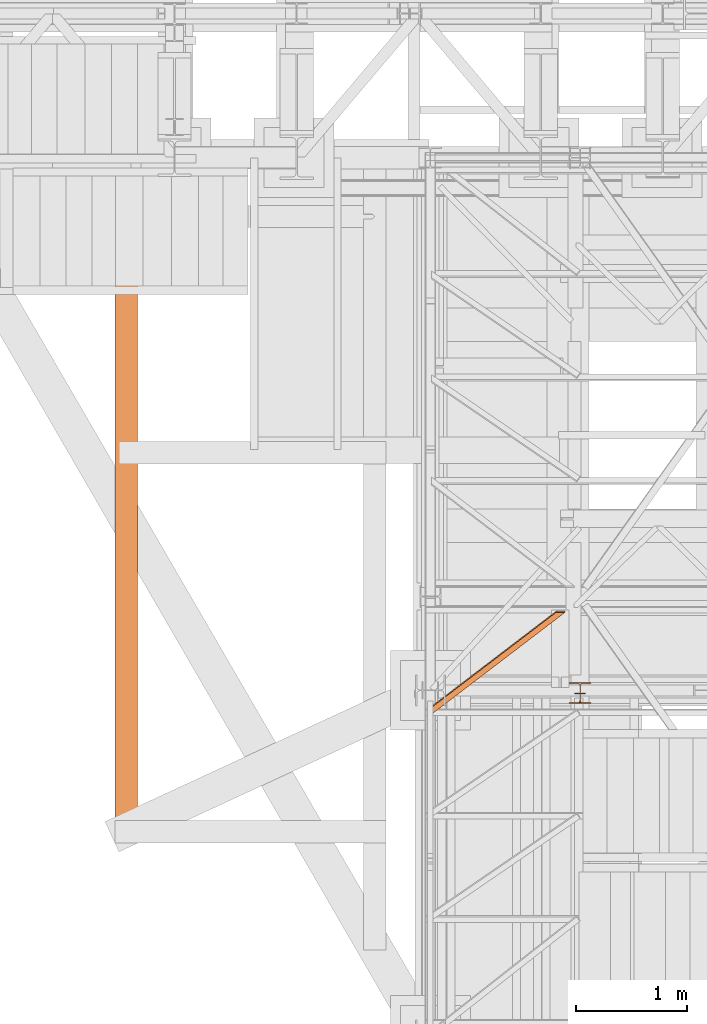
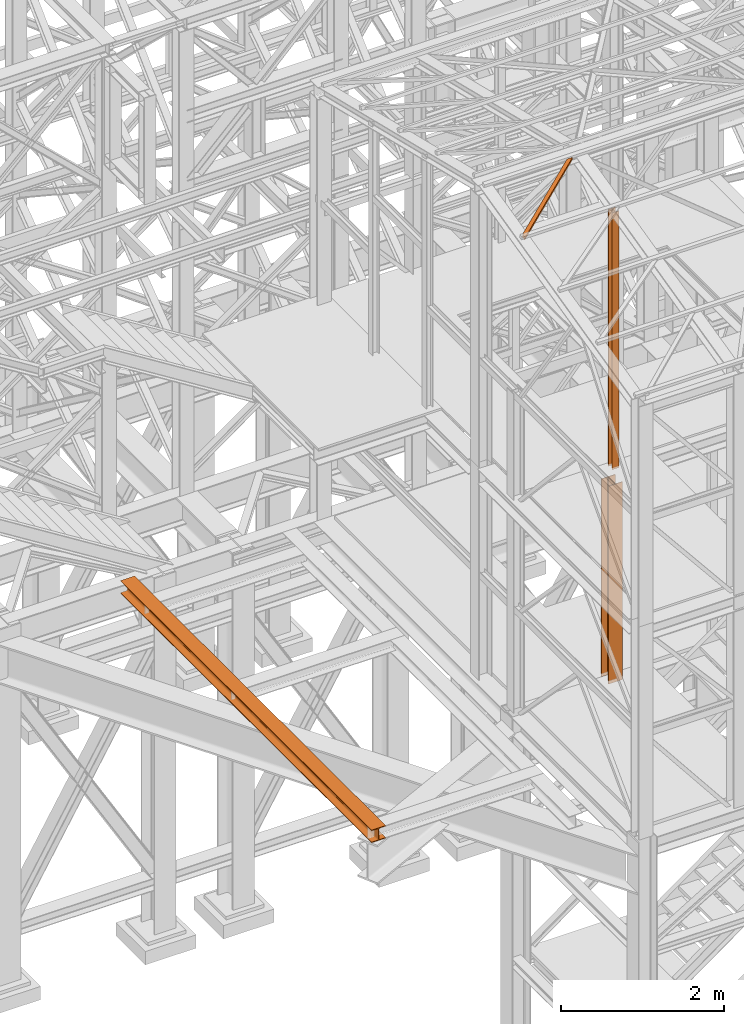
# One storey, part 16 of 208: 4 proxies.
"""IFC2X3 building model written with IfcOpenShell, lengths in millimetres."""

from ifc_helpers import new_model, entity, si_unit, converted_unit, frame, origin, origin_with_axes, place, context, subcontext, project, spatial, faceted_brep, element, save


model = new_model("IFC2X3")

# Units and contexts
model_context = context("Model", 3, precision=1e-05, world=origin())
plan_context = context("Plan", 3, precision=1e-05, world=origin())
body_context = subcontext(model_context, "Body", "Model", "MODEL_VIEW")
ifc_project = project(units=[si_unit("LENGTHUNIT", "METRE", prefix="MILLI"), converted_unit("PLANEANGLEUNIT", "DEGREE", entity("IfcPlaneAngleMeasure", 0.0174532925199433), si_unit("PLANEANGLEUNIT", "RADIAN"), dimensions=[0, 0, 0, 0, 0, 0, 0]), si_unit("AREAUNIT", "SQUARE_METRE"), si_unit("VOLUMEUNIT", "CUBIC_METRE")], contexts=[model_context, plan_context])

# Building, storey
building_placement = place(None, origin())
building = spatial("IfcBuilding", under=ifc_project, at=building_placement, CompositionType="COMPLEX")
storey_placement = place(building_placement, origin_with_axes())
storey = spatial("IfcBuildingStorey", under=building, at=storey_placement, Name="Geschoss", CompositionType="ELEMENT")

# Proxies
proxy_1_placement = place(storey_placement, frame((2448.254967038549, -22182.57439508626, 5284.990005364416), z_axis=(0.0, 0.0, 1.0), x_axis=(1.0, 0.0, 0.0)))
element("IfcBuildingElementProxy", 1, at=proxy_1_placement, inside=storey, context=body_context, shape_type="Brep", body=[
    faceted_brep([(0.01000000000021828, 190.0100125169738, 2970.00999254942), (200.0100029802325, 190.0100125169738, 2970.00999254942), (200.0100029802325, 180.0100146031364, 2970.00999254942), (121.2600035762789, 180.0100071525558, 2970.00999254942), (111.9441915473344, 178.1454621052726, 2970.00999254942), (105.1245498640838, 171.3258190250381, 2970.00999254942), (103.2600015571716, 162.0100079274162, 2970.00999254942), (103.2600015571716, 28.00999713897545, 2970.00999254942), (105.1245498640838, 18.69418604135353, 2970.00999254942), (111.9441915473344, 11.87454296111901, 2970.00999254942), (121.2600035762789, 10.00999791383583, 2970.00999254942), (200.0100029802325, 10.00999791383583, 2970.00999254942), (200.0100029802325, 0.00999999999839929, 2970.00999254942), (0.01000000000021828, 0.00999999999839929, 2970.00999254942), (0.01000000000021828, 10.00999791383583, 2970.00999254942), (78.75999940395377, 10.00999791383583, 2970.00999254942), (88.07581143289826, 11.87454296111901, 2970.00999254942), (94.89545311614893, 18.69418604135353, 2970.00999254942), (96.76000142306111, 28.00999713897545, 2970.00999254942), (96.76000142306111, 162.0100079274162, 2970.00999254942), (94.89545311614893, 171.3258190250381, 2970.00999254942), (88.07581143289826, 178.1454621052726, 2970.00999254942), (78.75999940395377, 180.0100071525558, 2970.00999254942), (0.01000000000021828, 180.0100146031364, 2970.00999254942), (200.0100029802325, 190.0100125169738, 2970.00999254942), (0.01000000000021828, 190.0100125169738, 2970.00999254942), (0.01000000000021828, 190.0100125169738, 0.009999999999308784), (200.0100029802325, 190.0100125169738, 0.009999999999308784), (200.0100029802325, 180.0100146031364, 2970.00999254942), (200.0100029802325, 190.0100125169738, 2970.00999254942), (200.0100029802325, 190.0100125169738, 0.009999999999308784), (200.0100029802325, 180.0100146031364, 0.009999999999308784), (121.2600035762789, 180.0100071525558, 2970.00999254942), (200.0100029802325, 180.0100146031364, 2970.00999254942), (200.0100029802325, 180.0100146031364, 0.009999999999308784), (121.2600035762789, 180.0100071525558, 0.009999999999308784), (111.9441915473344, 178.1454621052726, 2970.00999254942), (121.2600035762789, 180.0100071525558, 2970.00999254942), (121.2600035762789, 180.0100071525558, 0.009999999999308784), (111.9441915473344, 178.1454621052726, 0.009999999999308784), (105.1245498640838, 171.3258190250381, 2970.00999254942), (111.9441915473344, 178.1454621052726, 2970.00999254942), (111.9441915473344, 178.1454621052726, 0.009999999999308784), (105.1245498640838, 171.3258190250381, 0.009999999999308784), (103.2600015571716, 162.0100079274162, 2970.00999254942), (105.1245498640838, 171.3258190250381, 2970.00999254942), (105.1245498640838, 171.3258190250381, 0.009999999999308784), (103.2600015571716, 162.0100079274162, 0.009999999999308784), (103.2600015571716, 28.00999713897545, 2970.00999254942), (103.2600015571716, 162.0100079274162, 2970.00999254942), (103.2600015571716, 162.0100079274162, 0.009999999999308784), (103.2600015571716, 28.00999713897545, 0.009999999999308784), (105.1245498640838, 18.69418604135353, 2970.00999254942), (103.2600015571716, 28.00999713897545, 2970.00999254942), (103.2600015571716, 28.00999713897545, 0.009999999999308784), (105.1245498640838, 18.69418604135353, 0.009999999999308784), (111.9441915473344, 11.87454296111901, 2970.00999254942), (105.1245498640838, 18.69418604135353, 2970.00999254942), (105.1245498640838, 18.69418604135353, 0.009999999999308784), (111.9441915473344, 11.87454296111901, 0.009999999999308784), (121.2600035762789, 10.00999791383583, 2970.00999254942), (111.9441915473344, 11.87454296111901, 2970.00999254942), (111.9441915473344, 11.87454296111901, 0.009999999999308784), (121.2600035762789, 10.00999791383583, 0.009999999999308784), (200.0100029802325, 10.00999791383583, 2970.00999254942), (121.2600035762789, 10.00999791383583, 2970.00999254942), (121.2600035762789, 10.00999791383583, 0.009999999999308784), (200.0100029802325, 10.00999791383583, 0.009999999999308784), (200.0100029802325, 0.00999999999839929, 2970.00999254942), (200.0100029802325, 10.00999791383583, 2970.00999254942), (200.0100029802325, 10.00999791383583, 0.009999999999308784), (200.0100029802325, 0.00999999999839929, 0.009999999999308784), (0.01000000000021828, 0.00999999999839929, 2970.00999254942), (200.0100029802325, 0.00999999999839929, 2970.00999254942), (200.0100029802325, 0.00999999999839929, 0.009999999999308784), (0.01000000000021828, 0.00999999999839929, 0.009999999999308784), (0.01000000000021828, 10.00999791383583, 2970.00999254942), (0.01000000000021828, 0.00999999999839929, 2970.00999254942), (0.01000000000021828, 0.00999999999839929, 0.009999999999308784), (0.01000000000021828, 10.00999791383583, 0.009999999999308784), (78.75999940395377, 10.00999791383583, 2970.00999254942), (0.01000000000021828, 10.00999791383583, 2970.00999254942), (0.01000000000021828, 10.00999791383583, 0.009999999999308784), (78.75999940395377, 10.00999791383583, 0.009999999999308784), (88.07581143289826, 11.87454296111901, 2970.00999254942), (78.75999940395377, 10.00999791383583, 2970.00999254942), (78.75999940395377, 10.00999791383583, 0.009999999999308784), (88.07581143289826, 11.87454296111901, 0.009999999999308784), (94.89545311614893, 18.69418604135353, 2970.00999254942), (88.07581143289826, 11.87454296111901, 2970.00999254942), (88.07581143289826, 11.87454296111901, 0.009999999999308784), (94.89545311614893, 18.69418604135353, 0.009999999999308784), (96.76000142306111, 28.00999713897545, 2970.00999254942), (94.89545311614893, 18.69418604135353, 2970.00999254942), (94.89545311614893, 18.69418604135353, 0.009999999999308784), (96.76000142306111, 28.00999713897545, 0.009999999999308784), (96.76000142306111, 162.0100079274162, 2970.00999254942), (96.76000142306111, 28.00999713897545, 2970.00999254942), (96.76000142306111, 28.00999713897545, 0.009999999999308784), (96.76000142306111, 162.0100079274162, 0.009999999999308784), (94.89545311614893, 171.3258190250381, 2970.00999254942), (96.76000142306111, 162.0100079274162, 2970.00999254942), (96.76000142306111, 162.0100079274162, 0.009999999999308784), (94.89545311614893, 171.3258190250381, 0.009999999999308784), (88.07581143289826, 178.1454621052726, 2970.00999254942), (94.89545311614893, 171.3258190250381, 2970.00999254942), (94.89545311614893, 171.3258190250381, 0.009999999999308784), (88.07581143289826, 178.1454621052726, 0.009999999999308784), (78.75999940395377, 180.0100071525558, 2970.00999254942), (88.07581143289826, 178.1454621052726, 2970.00999254942), (88.07581143289826, 178.1454621052726, 0.009999999999308784), (78.75999940395377, 180.0100071525558, 0.009999999999308784), (0.01000000000021828, 180.0100146031364, 2970.00999254942), (78.75999940395377, 180.0100071525558, 2970.00999254942), (78.75999940395377, 180.0100071525558, 0.009999999999308784), (0.01000000000021828, 180.0100146031364, 0.009999999999308784), (0.01000000000021828, 190.0100125169738, 2970.00999254942), (0.01000000000021828, 180.0100146031364, 2970.00999254942), (0.01000000000021828, 180.0100146031364, 0.009999999999308784), (0.01000000000021828, 190.0100125169738, 0.009999999999308784), (0.01000000000021828, 190.0100125169738, 0.009999999999308784), (0.01000000000021828, 180.0100146031364, 0.009999999999308784), (78.75999940395377, 180.0100071525558, 0.009999999999308784), (88.07581143289826, 178.1454621052726, 0.009999999999308784), (94.89545311614893, 171.3258190250381, 0.009999999999308784), (96.76000142306111, 162.0100079274162, 0.009999999999308784), (96.76000142306111, 28.00999713897545, 0.009999999999308784), (94.89545311614893, 18.69418604135353, 0.009999999999308784), (88.07581143289826, 11.87454296111901, 0.009999999999308784), (78.75999940395377, 10.00999791383583, 0.009999999999308784), (0.01000000000021828, 10.00999791383583, 0.009999999999308784), (0.01000000000021828, 0.00999999999839929, 0.009999999999308784), (200.0100029802325, 0.00999999999839929, 0.009999999999308784), (200.0100029802325, 10.00999791383583, 0.009999999999308784), (121.2600035762789, 10.00999791383583, 0.009999999999308784), (111.9441915473344, 11.87454296111901, 0.009999999999308784), (105.1245498640838, 18.69418604135353, 0.009999999999308784), (103.2600015571716, 28.00999713897545, 0.009999999999308784), (103.2600015571716, 162.0100079274162, 0.009999999999308784), (105.1245498640838, 171.3258190250381, 0.009999999999308784), (111.9441915473344, 178.1454621052726, 0.009999999999308784), (121.2600035762789, 180.0100071525558, 0.009999999999308784), (200.0100029802325, 180.0100146031364, 0.009999999999308784), (200.0100029802325, 190.0100125169738, 0.009999999999308784)], [[[0, 1, 2, 3, 4, 5, 6, 7, 8, 9, 10, 11, 12, 13, 14, 15, 16, 17, 18, 19, 20, 21, 22, 23]], [[24, 25, 26, 27]], [[28, 29, 30, 31]], [[32, 33, 34, 35]], [[36, 37, 38, 39]], [[40, 41, 42, 43]], [[44, 45, 46, 47]], [[48, 49, 50, 51]], [[52, 53, 54, 55]], [[56, 57, 58, 59]], [[60, 61, 62, 63]], [[64, 65, 66, 67]], [[68, 69, 70, 71]], [[72, 73, 74, 75]], [[76, 77, 78, 79]], [[80, 81, 82, 83]], [[84, 85, 86, 87]], [[88, 89, 90, 91]], [[92, 93, 94, 95]], [[96, 97, 98, 99]], [[100, 101, 102, 103]], [[104, 105, 106, 107]], [[108, 109, 110, 111]], [[112, 113, 114, 115]], [[116, 117, 118, 119]], [[120, 121, 122, 123, 124, 125, 126, 127, 128, 129, 130, 131, 132, 133, 134, 135, 136, 137, 138, 139, 140, 141, 142, 143]]], orient=[[False], [False], [False], [False], [False], [False], [False], [False], [False], [False], [False], [False], [False], [False], [False], [False], [False], [False], [False], [False], [False], [False], [False], [False], [False], [False]]),
])
proxy_2_placement = place(storey_placement, frame((2498.31966389647, -22182.57439787535, 8484.990002086157), z_axis=(0.0, 0.0, 1.0), x_axis=(1.0, 0.0, 0.0)))
element("IfcBuildingElementProxy", 2, at=proxy_2_placement, inside=storey, context=body_context, shape_type="Brep", body=[
    faceted_brep([(0.01000000000021828, 8.010000000002037, 0.01000000000021828), (0.01000000000021828, 0.01000000000203727, 0.01000000000021828), (100.0100000000002, 0.01000000000203727, 0.01000000000021828), (100.0100000000002, 8.010000000002037, 0.01000000000021828), (52.51000000000022, 8.010000000002037, 0.01000000000021828), (52.51000000000022, 88.01000000000204, 0.01000000000021828), (100.0100000000002, 88.01000000000204, 0.01000000000021828), (100.0100000000002, 96.01000000000204, 0.01000000000021828), (0.01000000000021828, 96.01000000000204, 0.01000000000021828), (0.01000000000021828, 88.01000000000204, 0.01000000000021828), (47.51000000000022, 88.01000000000204, 0.01000000000021828), (47.51000000000022, 8.010000000002037, 0.01000000000021828), (0.01000000000021828, 0.01000000000203727, 0.01000000000021828), (0.01000000000021828, 8.010000000002037, 0.01000000000021828), (0.01000000000203727, 8.0099999999984, 3855.922025344464), (0.01000000000203727, 0.00999999999839929, 3855.922025344464), (100.0100000000002, 0.01000000000203727, 0.01000000000021828), (0.01000000000021828, 0.01000000000203727, 0.01000000000021828), (0.01000000000203727, 0.00999999999839929, 3855.922025344464), (100.010000000002, 0.00999999999839929, 3855.922025344464), (100.0100000000002, 8.010000000002037, 0.01000000000021828), (100.0100000000002, 0.01000000000203727, 0.01000000000021828), (100.010000000002, 0.00999999999839929, 3855.922025344464), (100.010000000002, 8.0099999999984, 3855.922025344464), (52.51000000000022, 8.010000000002037, 0.01000000000021828), (100.0100000000002, 8.010000000002037, 0.01000000000021828), (100.010000000002, 8.0099999999984, 3855.922025344464), (52.51000000000204, 8.0099999999984, 3855.922025344464), (52.51000000000022, 88.01000000000204, 0.01000000000021828), (52.51000000000022, 8.010000000002037, 0.01000000000021828), (52.51000000000204, 8.0099999999984, 3855.922025344464), (52.51000000000204, 88.0099999999984, 3855.922025344464), (100.0100000000002, 88.01000000000204, 0.01000000000021828), (52.51000000000022, 88.01000000000204, 0.01000000000021828), (52.51000000000204, 88.0099999999984, 3855.922025344464), (100.010000000002, 88.0099999999984, 3855.922025344464), (100.0100000000002, 96.01000000000204, 0.01000000000021828), (100.0100000000002, 88.01000000000204, 0.01000000000021828), (100.010000000002, 88.0099999999984, 3855.922025344464), (100.010000000002, 96.0099999999984, 3855.922025344464), (0.01000000000021828, 96.01000000000204, 0.01000000000021828), (100.0100000000002, 96.01000000000204, 0.01000000000021828), (100.010000000002, 96.0099999999984, 3855.922025344464), (0.01000000000203727, 96.0099999999984, 3855.922025344464), (0.01000000000021828, 88.01000000000204, 0.01000000000021828), (0.01000000000021828, 96.01000000000204, 0.01000000000021828), (0.01000000000203727, 96.0099999999984, 3855.922025344464), (0.01000000000203727, 88.0099999999984, 3855.922025344464), (47.51000000000022, 88.01000000000204, 0.01000000000021828), (0.01000000000021828, 88.01000000000204, 0.01000000000021828), (0.01000000000203727, 88.0099999999984, 3855.922025344464), (47.51000000000204, 88.0099999999984, 3855.922025344464), (47.51000000000022, 8.010000000002037, 0.01000000000021828), (47.51000000000022, 88.01000000000204, 0.01000000000021828), (47.51000000000204, 88.0099999999984, 3855.922025344464), (47.51000000000204, 8.0099999999984, 3855.922025344464), (0.01000000000021828, 8.010000000002037, 0.01000000000021828), (47.51000000000022, 8.010000000002037, 0.01000000000021828), (47.51000000000204, 8.0099999999984, 3855.922025344464), (0.01000000000203727, 8.0099999999984, 3855.922025344464), (0.01000000000203727, 8.0099999999984, 3855.922025344464), (47.51000000000204, 8.0099999999984, 3855.922025344464), (47.51000000000204, 88.0099999999984, 3855.922025344464), (0.01000000000203727, 88.0099999999984, 3855.922025344464), (0.01000000000203727, 96.0099999999984, 3855.922025344464), (100.010000000002, 96.0099999999984, 3855.922025344464), (100.010000000002, 88.0099999999984, 3855.922025344464), (52.51000000000204, 88.0099999999984, 3855.922025344464), (52.51000000000204, 8.0099999999984, 3855.922025344464), (100.010000000002, 8.0099999999984, 3855.922025344464), (100.010000000002, 0.00999999999839929, 3855.922025344464), (0.01000000000203727, 0.00999999999839929, 3855.922025344464)], [[[0, 1, 2, 3, 4, 5, 6, 7, 8, 9, 10, 11]], [[12, 13, 14, 15]], [[16, 17, 18, 19]], [[20, 21, 22, 23]], [[24, 25, 26, 27]], [[28, 29, 30, 31]], [[32, 33, 34, 35]], [[36, 37, 38, 39]], [[40, 41, 42, 43]], [[44, 45, 46, 47]], [[48, 49, 50, 51]], [[52, 53, 54, 55]], [[56, 57, 58, 59]], [[60, 61, 62, 63, 64, 65, 66, 67, 68, 69, 70, 71]]], orient=[[False], [False], [False], [False], [False], [False], [False], [False], [False], [False], [False], [False], [False], [False]]),
])
proxy_3_placement = place(storey_placement, frame((-1641.745031471337, -23437.50386180536, 5094.990005364416), z_axis=(0.0, 0.0, 1.0), x_axis=(1.0, 0.0, 0.0)))
element("IfcBuildingElementProxy", 3, at=proxy_3_placement, inside=storey, context=body_context, shape_type="Brep", body=[
    faceted_brep([(200.01, 6180.010000000002, 0.01000000000021828), (200.01, 0.01000000000203727, 0.01000000000021828), (200.01, 0.01000000000203727, 10.01000000000022), (200.01, 6180.010000000002, 10.01000000000022), (200.01, 6180.010000000002, 10.01000000000022), (200.01, 0.01000000000203727, 10.01000000000022), (121.26, 0.01000000000203727, 10.01000000000022), (121.26, 6180.010000000002, 10.01000000000022), (121.26, 6180.010000000002, 10.01000000000022), (121.26, 0.01000000000203727, 10.01000000000022), (115.6977129694258, 0.01000000000203727, 10.89104403849342), (115.6977129694258, 6180.010000000002, 10.89104403849342), (115.6977129694258, 6180.010000000002, 10.89104403849342), (115.6977129694258, 0.01000000000203727, 10.89104403849342), (110.6798832894654, 0.01000000000203727, 13.44771635773213), (110.6798832894654, 6180.010000000002, 13.44771635773213), (110.6798832894654, 6180.010000000002, 13.44771635773213), (110.6798832894654, 0.01000000000203727, 13.44771635773213), (106.6977163577337, 0.01000000000203727, 17.42988328946558), (106.6977163577337, 6180.010000000002, 17.42988328946558), (106.6977163577337, 6180.010000000002, 17.42988328946558), (106.6977163577337, 0.01000000000203727, 17.42988328946558), (104.141044038495, 0.01000000000203727, 22.44771296942599), (104.141044038495, 6180.010000000002, 22.44771296942599), (104.141044038495, 6180.010000000002, 22.44771296942599), (104.141044038495, 0.01000000000203727, 22.44771296942599), (103.26, 0.01000000000203727, 28.01000000000022), (103.26, 6180.010000000002, 28.01000000000022), (103.26, 6180.010000000002, 28.01000000000022), (103.26, 0.01000000000203727, 28.01000000000022), (103.26, 0.01000000000203727, 162.0100000000002), (103.26, 6180.010000000002, 162.0100000000002), (103.26, 6180.010000000002, 162.0100000000002), (103.26, 0.01000000000203727, 162.0100000000002), (104.141044038495, 0.01000000000203727, 167.5722870305744), (104.141044038495, 6180.010000000002, 167.5722870305744), (104.141044038495, 6180.010000000002, 167.5722870305744), (104.141044038495, 0.01000000000203727, 167.5722870305744), (106.6977163577337, 0.01000000000203727, 172.5901167105349), (106.6977163577337, 6180.010000000002, 172.5901167105349), (106.6977163577337, 6180.010000000002, 172.5901167105349), (106.6977163577337, 0.01000000000203727, 172.5901167105349), (110.6798832894672, 0.01000000000203727, 176.5722836422674), (110.6798832894654, 6180.010000000002, 176.5722836422683), (110.6798832894654, 6180.010000000002, 176.5722836422683), (110.6798832894672, 0.01000000000203727, 176.5722836422674), (115.6977129694258, 0.01000000000203727, 179.128955961507), (115.6977129694258, 6180.010000000002, 179.128955961507), (115.6977129694258, 6180.010000000002, 179.128955961507), (115.6977129694258, 0.01000000000203727, 179.128955961507), (120.01, 0.01000000000203727, 180.0100000000002), (120.01, 6180.010000000002, 180.0100000000002), (120.01, 6180.010000000002, 180.0100000000002), (120.01, 0.01000000000203727, 180.0100000000002), (200.01, 0.01000000000203727, 180.0100000000002), (200.01, 6180.010000000002, 180.0100000000002), (200.01, 6180.010000000002, 180.0100000000002), (200.01, 0.01000000000203727, 180.0100000000002), (200.01, 0.01000000000203727, 190.0100000000002), (200.01, 6180.010000000002, 190.0100000000002), (200.01, 6180.010000000002, 190.0100000000002), (200.01, 0.01000000000203727, 190.0100000000002), (0.009999999999990905, 0.01000000000203727, 190.0100000000002), (0.009999999999990905, 6180.010000000002, 190.0100000000002), (0.009999999999990905, 6180.010000000002, 190.0100000000002), (0.009999999999990905, 0.01000000000203727, 190.0100000000002), (0.009999999999990905, 0.01000000000203727, 180.0100000000002), (0.009999999999990905, 6180.010000000002, 180.0100000000002), (0.009999999999990905, 6180.010000000002, 180.0100000000002), (0.009999999999990905, 0.01000000000203727, 180.0100000000002), (78.75999999999999, 0.01000000000203727, 180.0100000000002), (78.75999999999999, 6180.010000000002, 180.0100000000002), (78.75999999999999, 6180.010000000002, 180.0100000000002), (78.75999999999999, 0.01000000000203727, 180.0100000000002), (84.32228703057422, 0.01000000000203727, 179.128955961507), (84.32228703057422, 6180.010000000002, 179.128955961507), (84.32228703057422, 6180.010000000002, 179.128955961507), (84.32228703057422, 0.01000000000203727, 179.128955961507), (89.34011671053463, 0.01000000000203727, 176.5722836422683), (89.34011671053463, 6180.010000000002, 176.5722836422683), (89.34011671053463, 6180.010000000002, 176.5722836422683), (89.34011671053463, 0.01000000000203727, 176.5722836422683), (93.32228364227171, 0.01000000000203727, 172.5901167105349), (93.3222836422699, 6180.010000000002, 172.5901167105349), (93.3222836422699, 6180.010000000002, 172.5901167105349), (93.32228364227171, 0.01000000000203727, 172.5901167105349), (95.87895596150497, 0.01000000000203727, 167.5722870305744), (95.87895596150497, 6180.010000000002, 167.5722870305744), (95.87895596150497, 6180.010000000002, 167.5722870305744), (95.87895596150497, 0.01000000000203727, 167.5722870305744), (96.75999999999999, 0.01000000000203727, 162.0100000000002), (96.75999999999999, 6180.010000000002, 162.0100000000002), (96.75999999999999, 6180.010000000002, 162.0100000000002), (96.75999999999999, 0.01000000000203727, 162.0100000000002), (96.75999999999999, 0.01000000000203727, 28.01000000000022), (96.75999999999999, 6180.010000000002, 28.01000000000022), (96.75999999999999, 6180.010000000002, 28.01000000000022), (96.75999999999999, 0.01000000000203727, 28.01000000000022), (95.87895596150497, 0.01000000000203727, 22.44771296942599), (95.87895596150497, 6180.010000000002, 22.44771296942599), (95.87895596150497, 6180.010000000002, 22.44771296942599), (95.87895596150497, 0.01000000000203727, 22.44771296942599), (93.3222836422699, 0.01000000000203727, 17.42988328946558), (93.3222836422699, 6180.010000000002, 17.42988328946558), (93.3222836422699, 6180.010000000002, 17.42988328946558), (93.3222836422699, 0.01000000000203727, 17.42988328946558), (89.34011671053463, 0.01000000000203727, 13.44771635773213), (89.34011671053463, 6180.010000000002, 13.44771635773213), (89.34011671053463, 6180.010000000002, 13.44771635773213), (89.34011671053463, 0.01000000000203727, 13.44771635773213), (84.32228703057422, 0.01000000000203727, 10.89104403849342), (84.32228703057422, 6180.010000000002, 10.89104403849342), (84.32228703057422, 6180.010000000002, 10.89104403849342), (84.32228703057422, 0.01000000000203727, 10.89104403849342), (78.75999999999999, 0.01000000000203727, 10.01000000000022), (78.75999999999999, 6180.010000000002, 10.01000000000022), (78.75999999999999, 6180.010000000002, 10.01000000000022), (78.75999999999999, 0.01000000000203727, 10.01000000000022), (0.009999999999990905, 0.01000000000203727, 10.01000000000022), (0.009999999999990905, 6180.010000000002, 10.01000000000022), (0.009999999999990905, 6180.010000000002, 10.01000000000022), (0.009999999999990905, 0.01000000000203727, 10.01000000000022), (0.009999999999990905, 0.01000000000203727, 0.01000000000021828), (0.009999999999990905, 6180.010000000002, 0.01000000000021828), (0.009999999999990905, 6180.010000000002, 0.01000000000021828), (0.009999999999990905, 0.01000000000203727, 0.01000000000021828), (200.01, 0.01000000000203727, 0.01000000000021828), (200.01, 6180.010000000002, 0.01000000000021828), (200.01, 6180.010000000002, 0.01000000000021828), (200.01, 6180.010000000002, 10.01000000000022), (121.26, 6180.010000000002, 10.01000000000022), (115.6977129694258, 6180.010000000002, 10.89104403849342), (110.6798832894654, 6180.010000000002, 13.44771635773213), (106.6977163577337, 6180.010000000002, 17.42988328946558), (104.141044038495, 6180.010000000002, 22.44771296942599), (103.26, 6180.010000000002, 28.01000000000022), (103.26, 6180.010000000002, 162.0100000000002), (104.141044038495, 6180.010000000002, 167.5722870305744), (106.6977163577337, 6180.010000000002, 172.5901167105349), (110.6798832894654, 6180.010000000002, 176.5722836422683), (115.6977129694258, 6180.010000000002, 179.128955961507), (120.01, 6180.010000000002, 180.0100000000002), (200.01, 6180.010000000002, 180.0100000000002), (200.01, 6180.010000000002, 190.0100000000002), (0.009999999999990905, 6180.010000000002, 190.0100000000002), (0.009999999999990905, 6180.010000000002, 180.0100000000002), (78.75999999999999, 6180.010000000002, 180.0100000000002), (84.32228703057422, 6180.010000000002, 179.128955961507), (89.34011671053463, 6180.010000000002, 176.5722836422683), (93.3222836422699, 6180.010000000002, 172.5901167105349), (95.87895596150497, 6180.010000000002, 167.5722870305744), (96.75999999999999, 6180.010000000002, 162.0100000000002), (96.75999999999999, 6180.010000000002, 28.01000000000022), (95.87895596150497, 6180.010000000002, 22.44771296942599), (93.3222836422699, 6180.010000000002, 17.42988328946558), (89.34011671053463, 6180.010000000002, 13.44771635773213), (84.32228703057422, 6180.010000000002, 10.89104403849342), (78.75999999999999, 6180.010000000002, 10.01000000000022), (0.009999999999990905, 6180.010000000002, 10.01000000000022), (0.009999999999990905, 6180.010000000002, 0.01000000000021828), (200.01, 0.01000000000203727, 0.01000000000021828), (0.009999999999990905, 0.01000000000203727, 0.01000000000021828), (0.009999999999990905, 0.01000000000203727, 10.01000000000022), (78.75999999999999, 0.01000000000203727, 10.01000000000022), (84.32228703057422, 0.01000000000203727, 10.89104403849342), (89.34011671053463, 0.01000000000203727, 13.44771635773213), (93.3222836422699, 0.01000000000203727, 17.42988328946558), (95.87895596150497, 0.01000000000203727, 22.44771296942599), (96.75999999999999, 0.01000000000203727, 28.01000000000022), (96.75999999999999, 0.01000000000203727, 162.0100000000002), (95.87895596150497, 0.01000000000203727, 167.5722870305744), (93.32228364227171, 0.01000000000203727, 172.5901167105349), (89.34011671053463, 0.01000000000203727, 176.5722836422683), (84.32228703057422, 0.01000000000203727, 179.128955961507), (78.75999999999999, 0.01000000000203727, 180.0100000000002), (0.009999999999990905, 0.01000000000203727, 180.0100000000002), (0.009999999999990905, 0.01000000000203727, 190.0100000000002), (200.01, 0.01000000000203727, 190.0100000000002), (200.01, 0.01000000000203727, 180.0100000000002), (120.01, 0.01000000000203727, 180.0100000000002), (115.6977129694258, 0.01000000000203727, 179.128955961507), (110.6798832894672, 0.01000000000203727, 176.5722836422674), (106.6977163577337, 0.01000000000203727, 172.5901167105349), (104.141044038495, 0.01000000000203727, 167.5722870305744), (103.26, 0.01000000000203727, 162.0100000000002), (103.26, 0.01000000000203727, 28.01000000000022), (104.141044038495, 0.01000000000203727, 22.44771296942599), (106.6977163577337, 0.01000000000203727, 17.42988328946558), (110.6798832894654, 0.01000000000203727, 13.44771635773213), (115.6977129694258, 0.01000000000203727, 10.89104403849342), (121.26, 0.01000000000203727, 10.01000000000022), (200.01, 0.01000000000203727, 10.01000000000022)], [[[0, 1, 2, 3]], [[4, 5, 6, 7]], [[8, 9, 10, 11]], [[12, 13, 14, 15]], [[16, 17, 18, 19]], [[20, 21, 22, 23]], [[24, 25, 26, 27]], [[28, 29, 30, 31]], [[32, 33, 34, 35]], [[36, 37, 38, 39]], [[40, 41, 42, 43]], [[44, 45, 46, 47]], [[48, 49, 50, 51]], [[52, 53, 54, 55]], [[56, 57, 58, 59]], [[60, 61, 62, 63]], [[64, 65, 66, 67]], [[68, 69, 70, 71]], [[72, 73, 74, 75]], [[76, 77, 78, 79]], [[80, 81, 82, 83]], [[84, 85, 86, 87]], [[88, 89, 90, 91]], [[92, 93, 94, 95]], [[96, 97, 98, 99]], [[100, 101, 102, 103]], [[104, 105, 106, 107]], [[108, 109, 110, 111]], [[112, 113, 114, 115]], [[116, 117, 118, 119]], [[120, 121, 122, 123]], [[124, 125, 126, 127]], [[128, 129, 130, 131, 132, 133, 134, 135, 136, 137, 138, 139, 140, 141, 142, 143, 144, 145, 146, 147, 148, 149, 150, 151, 152, 153, 154, 155, 156, 157, 158, 159]], [[160, 161, 162, 163, 164, 165, 166, 167, 168, 169, 170, 171, 172, 173, 174, 175, 176, 177, 178, 179, 180, 181, 182, 183, 184, 185, 186, 187, 188, 189, 190, 191]]], orient=[[False], [False], [False], [False], [False], [False], [False], [False], [False], [False], [False], [False], [False], [False], [False], [False], [False], [False], [False], [False], [False], [False], [False], [False], [False], [False], [False], [False], [False], [False], [False], [False], [False], [False]]),
])
proxy_4_placement = place(storey_placement, frame((1206.57338904654, -22278.63157839609, 12438.25044331833), z_axis=(0.0, 0.0, 1.0), x_axis=(1.0, 0.0, 0.0)))
element("IfcBuildingElementProxy", 4, at=proxy_4_placement, inside=storey, context=body_context, shape_type="Brep", body=[
    faceted_brep([(0.2573532659832836, 71.07412996872154, 14.22569010463849), (1125.699094526467, 930.0080381721091, 225.6853668124295), (1125.258902473616, 918.2142876387588, 274.2731619784845), (0.009999999999990905, 59.42755344428588, 62.84971782368302), (3.438929976495956, 11.65657652443406, 0.01000000000021828), (1206.610437699371, 929.9136194966668, 226.0743520846791), (1125.699094526467, 930.0080381721091, 225.6853668124295), (0.2573532659832836, 71.07412996872154, 14.22569010463849), (3.191576710513573, 0.00999999999839929, 48.63402771904111), (1206.170245646521, 918.1198689633202, 274.6621472507304), (1206.610437699371, 929.9136194966668, 226.0743520846791), (3.438929976495956, 11.65657652443406, 0.01000000000021828), (0.009999999999990905, 59.42755344428588, 62.84971782368302), (1125.258902473616, 918.2142876387588, 274.2731619784845), (1206.170245646521, 918.1198689633202, 274.6621472507304), (3.191576710513573, 0.00999999999839929, 48.63402771904111), (0.2573532659832836, 71.07412996872154, 14.22569010463849), (0.009999999999990905, 59.42755344428588, 62.84971782368302), (3.191576710513573, 0.00999999999839929, 48.63402771904111), (3.438929976495956, 11.65657652443406, 0.01000000000021828), (1125.258902473616, 918.2142876387588, 274.2731619784845), (1125.699094526467, 930.0080381721091, 225.6853668124295), (1206.610437699371, 929.9136194966668, 226.0743520846791), (1206.170245646521, 918.1198689633202, 274.6621472507304)], [[[0, 1, 2, 3]], [[4, 5, 6, 7]], [[8, 9, 10, 11]], [[12, 13, 14, 15]], [[16, 17, 18, 19]], [[20, 21, 22, 23]]], orient=[[False], [False], [False], [False], [False], [False]]),
])

save(model, "model.ifc")
